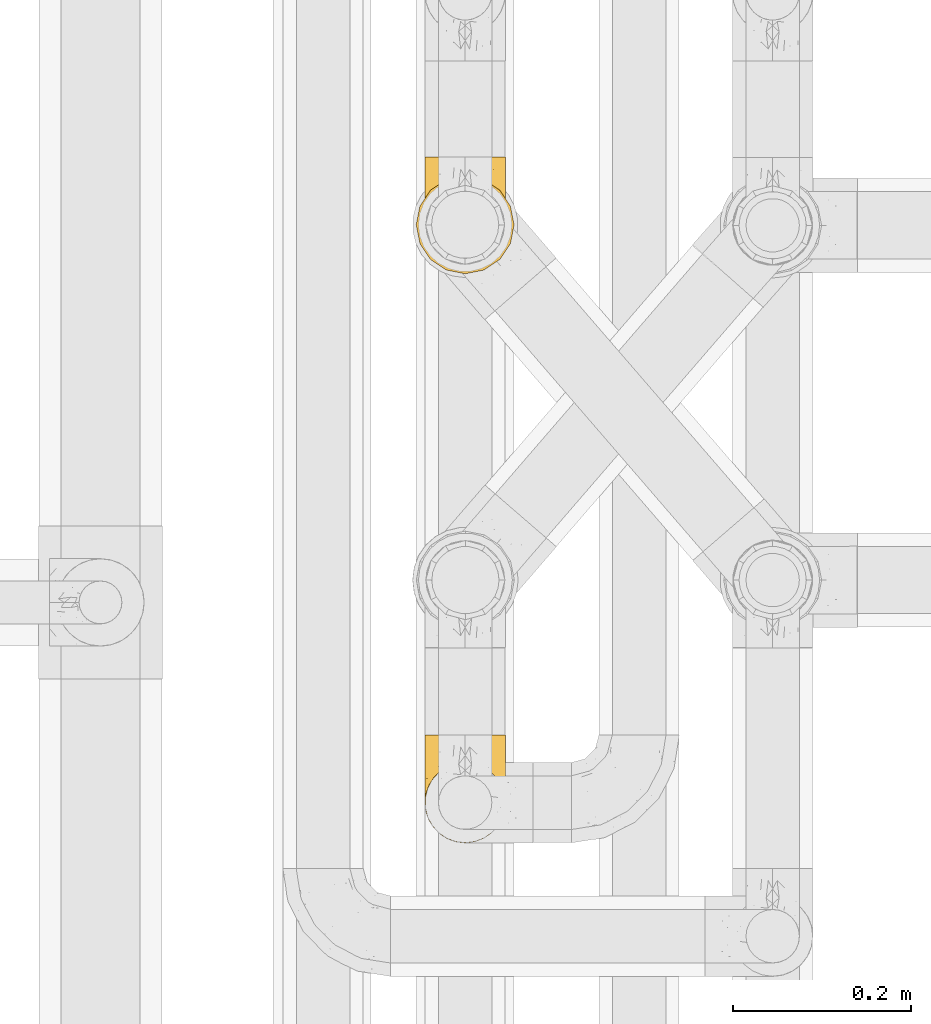
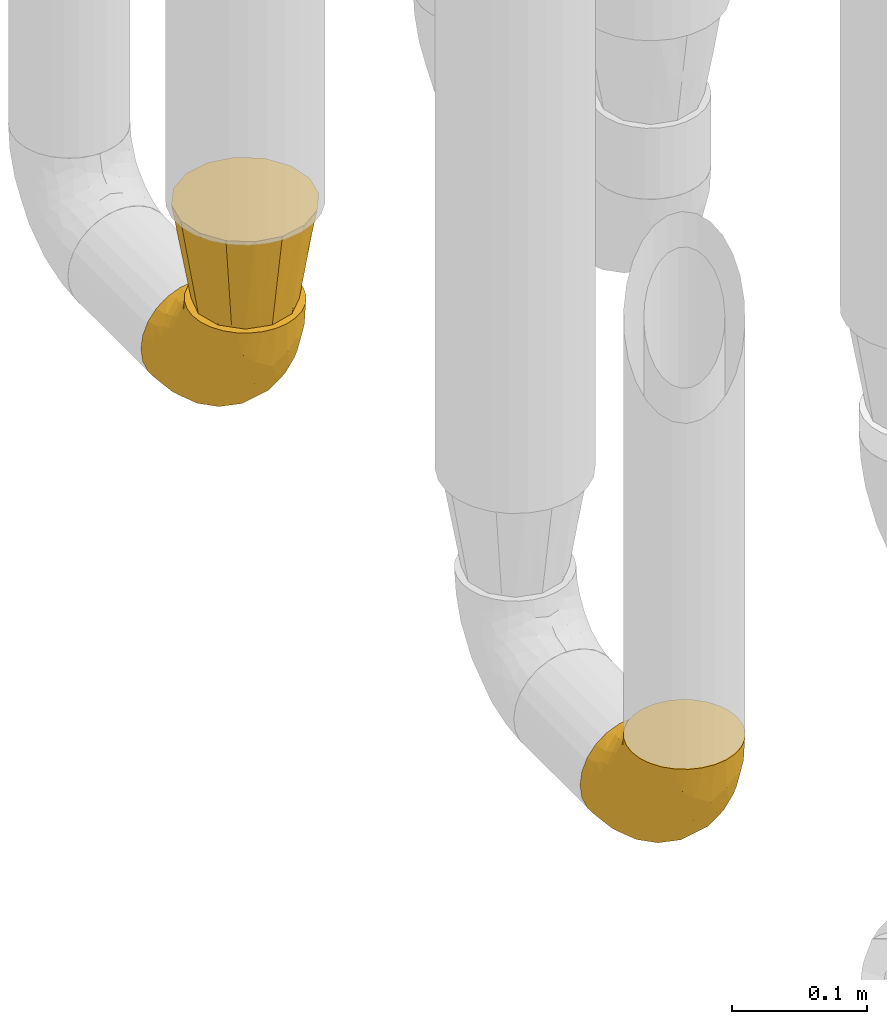
# One storey, part 227 of 827: 3 coverings.
"""IFC2X3 building model written with IfcOpenShell, lengths in millimetres."""

from ifc_helpers import new_model, entity, si_unit, converted_unit, derived_unit, direction, frame, origin, place, context, subcontext, project, spatial, faceted_brep, element, save


model = new_model("IFC2X3")

# Units and contexts
model_context = context("Model", 3, precision=0.01, world=origin(), true_north=direction((6.12303176911189e-17, 1.0)))
body_context = subcontext(model_context, "Body", "Model", "MODEL_VIEW")
ifc_project = project(units=[si_unit("LENGTHUNIT", "METRE", prefix="MILLI"), si_unit("AREAUNIT", "SQUARE_METRE"), si_unit("VOLUMEUNIT", "CUBIC_METRE"), converted_unit("PLANEANGLEUNIT", "DEGREE", entity("IfcRatioMeasure", 0.0174532925199433), si_unit("PLANEANGLEUNIT", "RADIAN"), dimensions=[0, 0, 0, 0, 0, 0, 0]), si_unit("MASSUNIT", "GRAM", prefix="KILO"), derived_unit("MASSDENSITYUNIT", [(si_unit("MASSUNIT", "GRAM", prefix="KILO"), 1), (si_unit("LENGTHUNIT", "METRE"), -3)]), derived_unit("MOMENTOFINERTIAUNIT", [(si_unit("LENGTHUNIT", "METRE"), 4)]), si_unit("TIMEUNIT", "SECOND"), si_unit("FREQUENCYUNIT", "HERTZ"), si_unit("THERMODYNAMICTEMPERATUREUNIT", "DEGREE_CELSIUS"), derived_unit("THERMALTRANSMITTANCEUNIT", [(si_unit("MASSUNIT", "GRAM", prefix="KILO"), 1), (si_unit("THERMODYNAMICTEMPERATUREUNIT", "KELVIN"), -1), (si_unit("TIMEUNIT", "SECOND"), -3)]), derived_unit("VOLUMETRICFLOWRATEUNIT", [(si_unit("LENGTHUNIT", "METRE"), 3), (si_unit("TIMEUNIT", "SECOND"), -1)]), derived_unit("MASSFLOWRATEUNIT", [(si_unit("MASSUNIT", "GRAM", prefix="KILO"), 1), (si_unit("TIMEUNIT", "SECOND"), -1)]), derived_unit("ROTATIONALFREQUENCYUNIT", [(si_unit("TIMEUNIT", "SECOND"), -1)]), si_unit("ELECTRICCURRENTUNIT", "AMPERE"), si_unit("ELECTRICVOLTAGEUNIT", "VOLT"), si_unit("POWERUNIT", "WATT"), si_unit("FORCEUNIT", "NEWTON", prefix="KILO"), si_unit("ILLUMINANCEUNIT", "LUX"), si_unit("LUMINOUSFLUXUNIT", "LUMEN"), si_unit("LUMINOUSINTENSITYUNIT", "CANDELA"), derived_unit("USERDEFINED", [(si_unit("MASSUNIT", "GRAM", prefix="KILO"), -1), (si_unit("LENGTHUNIT", "METRE"), -2), (si_unit("TIMEUNIT", "SECOND"), 3), (si_unit("LUMINOUSFLUXUNIT", "LUMEN"), 1)]), derived_unit("LINEARVELOCITYUNIT", [(si_unit("LENGTHUNIT", "METRE"), 1), (si_unit("TIMEUNIT", "SECOND"), -1)]), si_unit("PRESSUREUNIT", "PASCAL"), derived_unit("USERDEFINED", [(si_unit("LENGTHUNIT", "METRE"), -2), (si_unit("MASSUNIT", "GRAM", prefix="KILO"), 1), (si_unit("TIMEUNIT", "SECOND"), -2)]), derived_unit("LINEARFORCEUNIT", [(si_unit("MASSUNIT", "GRAM", prefix="KILO"), 1), (si_unit("LENGTHUNIT", "METRE"), 1), (si_unit("TIMEUNIT", "SECOND"), -2), (si_unit("LENGTHUNIT", "METRE"), -1)]), derived_unit("PLANARFORCEUNIT", [(si_unit("MASSUNIT", "GRAM", prefix="KILO"), 1), (si_unit("LENGTHUNIT", "METRE"), 1), (si_unit("TIMEUNIT", "SECOND"), -2), (si_unit("LENGTHUNIT", "METRE"), -2)])], contexts=[model_context])

# Site, building, storey
site_placement = place(None, origin())
site = spatial("IfcSite", under=ifc_project, at=site_placement, CompositionType="ELEMENT")
building_placement = place(site_placement, origin())
building = spatial("IfcBuilding", under=site, at=building_placement, CompositionType="ELEMENT")
storey_placement = place(building_placement, frame((0.0, 0.0, 28200.0)))
storey = spatial("IfcBuildingStorey", under=building, at=storey_placement, Name="08", CompositionType="ELEMENT", Elevation=28200.0)

# Coverings
covering_1_placement = place(storey_placement, frame((36582.9, 12933.46, 353.25)))
element("IfcCovering", 1, at=covering_1_placement, inside=storey, Name=":ADSK_", ObjectType=":ADSK_", PredefinedType="INSULATION", context=body_context, shape_type="Brep", body=[
    faceted_brep([(2.73, 36.69, 122.75), (6.07, 27.15, 122.75), (11.45, 18.59, 122.75), (18.6, 11.44, 122.75), (27.16, 6.06, 122.75), (36.7, 2.73, 122.75), (46.75, 1.6, 122.75), (56.8, 2.73, 122.75), (66.34, 6.07, 122.75), (74.9, 11.45, 122.75), (82.05, 18.6, 122.75), (87.43, 27.16, 122.75), (90.76, 36.7, 122.75), (91.9, 46.75, 122.75), (90.76, 56.8, 122.75), (87.42, 66.34, 122.75), (82.04, 74.9, 122.75), (74.89, 82.05, 122.75), (66.33, 87.43, 122.75), (56.79, 90.76, 122.75), (46.75, 91.9, 122.75), (36.69, 90.76, 122.75), (27.15, 87.42, 122.75), (18.59, 82.04, 122.75), (11.44, 74.89, 122.75), (6.06, 66.33, 122.75), (2.73, 56.79, 122.75), (1.6, 46.75, 122.75), (58.43, 122.75, 90.36), (69.32, 122.75, 85.85), (78.67, 122.75, 78.67), (85.85, 122.75, 69.32), (90.36, 122.75, 58.43), (91.9, 122.75, 46.75), (90.36, 122.75, 35.06), (85.85, 122.75, 24.17), (78.67, 122.75, 14.82), (69.32, 122.75, 7.64), (58.43, 122.75, 3.13), (46.75, 122.75, 1.6), (35.06, 122.75, 3.13), (24.17, 122.75, 7.64), (14.82, 122.75, 14.82), (7.64, 122.75, 24.17), (3.13, 122.75, 35.06), (1.6, 122.75, 46.75), (3.13, 122.75, 58.43), (7.64, 122.75, 69.32), (14.82, 122.75, 78.67), (24.17, 122.75, 85.85), (35.06, 122.75, 90.36), (46.75, 122.75, 91.9), (46.75, 24.73, 51.54), (38.29, 29.08, 47.17), (46.75, 38.13, 38.13), (46.75, 85.31, 7.52), (38.96, 93.59, 5.85), (46.75, 100.54, 5.11), (33.86, 63.54, 19.2), (31.42, 38.98, 38.98), (21.63, 50.71, 35.02), (30.84, 93.33, 8.21), (22.16, 75.2, 19.28), (20.56, 100.46, 12.19), (2.29, 41.6, 101.39), (7.18, 80.86, 34.43), (12.6, 94.87, 20.95), (14.0, 67.96, 30.74), (2.81, 52.16, 72.93), (6.65, 52.1, 56.64), (6.11, 36.74, 80.81), (16.62, 17.11, 93.43), (9.76, 23.24, 100.76), (12.46, 29.18, 74.27), (1.6, 52.53, 93.66), (1.6, 60.77, 81.33), (1.6, 69.01, 69.01), (2.46, 100.68, 40.87), (5.91, 103.79, 29.38), (36.97, 16.37, 67.05), (46.75, 7.52, 85.31), (33.09, 7.31, 93.68), (1.6, 93.66, 52.53), (1.6, 102.83, 50.71), (1.6, 112.01, 48.88), (25.62, 18.17, 72.77), (3.14, 71.97, 51.21), (23.92, 9.83, 101.18), (46.75, 5.11, 100.54), (13.58, 45.97, 48.74), (1.6, 48.88, 112.01), (1.6, 50.71, 102.83), (18.5, 22.83, 73.88), (46.75, 51.54, 24.73), (1.6, 81.33, 60.77), (4.96, 31.74, 103.08), (20.84, 32.48, 54.8), (46.75, 68.42, 16.13), (30.52, 25.33, 55.92), (46.75, 16.13, 68.42), (27.29, 92.29, 104.98), (36.89, 94.12, 108.58), (33.6, 100.97, 98.21), (2.54, 95.91, 61.56), (3.27, 107.9, 60.69), (16.85, 87.24, 100.0), (21.91, 95.46, 95.88), (13.5, 90.41, 90.81), (3.96, 74.17, 84.88), (3.52, 83.77, 73.29), (12.17, 76.72, 113.4), (18.93, 84.44, 109.8), (9.34, 76.42, 102.13), (3.12, 90.07, 67.29), (5.67, 99.69, 70.34), (2.51, 61.74, 95.15), (2.53, 58.16, 105.49), (8.35, 112.6, 71.5), (35.39, 110.45, 92.87), (46.75, 107.32, 96.03), (15.1, 108.48, 81.34), (5.27, 66.63, 107.44), (27.43, 115.23, 88.36), (24.89, 105.79, 90.43), (29.71, 89.6, 114.37), (5.07, 69.39, 98.41), (2.88, 66.99, 88.73), (9.69, 102.31, 76.89), (15.51, 99.54, 86.08), (2.27, 55.27, 112.64), (10.03, 82.03, 94.21), (46.75, 94.71, 112.22), (46.75, 96.03, 107.32), (8.83, 94.11, 79.95), (7.16, 84.21, 84.51), (46.75, 101.67, 101.67), (46.75, 112.22, 94.71), (78.39, 108.48, 81.34), (83.8, 102.31, 76.89), (77.97, 99.54, 86.08), (84.66, 94.11, 79.96), (58.1, 110.46, 92.87), (81.31, 76.74, 113.41), (91.9, 50.71, 102.83), (90.96, 58.17, 105.5), (91.22, 55.27, 112.64), (56.59, 94.12, 108.58), (66.18, 92.3, 104.98), (59.87, 100.98, 98.2), (88.42, 69.41, 98.4), (84.13, 76.44, 102.13), (88.22, 66.65, 107.44), (66.06, 115.24, 88.36), (91.9, 102.83, 50.71), (91.9, 112.01, 48.88), (83.44, 82.05, 94.22), (76.62, 87.25, 100.01), (85.14, 112.6, 71.5), (90.22, 107.9, 60.69), (91.9, 93.66, 52.53), (71.55, 95.48, 95.89), (63.77, 89.6, 114.37), (91.9, 60.77, 81.33), (91.9, 69.01, 69.01), (89.53, 74.17, 84.88), (91.9, 48.88, 112.01), (74.55, 84.45, 109.8), (90.95, 95.91, 61.56), (90.37, 90.07, 67.29), (91.9, 81.33, 60.77), (90.98, 61.75, 95.14), (89.97, 83.77, 73.29), (86.32, 84.21, 84.53), (91.9, 52.53, 93.66), (79.97, 90.42, 90.82), (90.61, 67.0, 88.73), (87.82, 99.69, 70.34), (68.6, 105.8, 90.43), (80.89, 94.87, 20.95), (86.31, 80.86, 34.43), (79.49, 67.95, 30.74), (71.33, 75.17, 19.29), (71.88, 50.65, 35.07), (90.35, 71.97, 51.21), (86.85, 52.08, 56.67), (72.67, 32.46, 54.85), (62.08, 38.98, 38.98), (87.58, 103.79, 29.38), (91.03, 100.68, 40.87), (59.62, 63.54, 19.2), (62.65, 93.32, 8.21), (54.53, 93.59, 5.85), (72.93, 100.44, 12.19), (90.68, 52.17, 72.93), (87.39, 36.75, 80.83), (91.2, 41.61, 101.39), (60.41, 7.31, 93.69), (76.88, 17.12, 93.43), (56.53, 16.37, 67.04), (83.74, 23.26, 100.76), (67.88, 18.17, 72.78), (62.99, 25.33, 55.93), (69.58, 9.84, 101.18), (81.04, 29.19, 74.27), (75.0, 22.84, 73.89), (88.53, 31.75, 103.09), (79.93, 45.96, 48.78), (55.21, 29.07, 47.19)], [[[0, 1, 2, 3, 4, 5, 6, 7, 8, 9, 10, 11, 12, 13, 14, 15, 16, 17, 18, 19, 20, 21, 22, 23, 24, 25, 26, 27]], [[28, 29, 30, 31, 32, 33, 34, 35, 36, 37, 38, 39, 40, 41, 42, 43, 44, 45, 46, 47, 48, 49, 50, 51]], [[52, 53, 54]], [[55, 56, 57]], [[58, 59, 60]], [[61, 62, 63]], [[27, 64, 0]], [[65, 66, 67]], [[41, 40, 61]], [[68, 69, 70]], [[66, 43, 42]], [[63, 42, 41]], [[71, 72, 73]], [[72, 2, 1]], [[68, 74, 75, 76]], [[45, 44, 77]], [[43, 78, 44]], [[79, 80, 81]], [[77, 82, 83, 84, 45]], [[79, 81, 85]], [[71, 2, 72]], [[65, 86, 77]], [[4, 81, 5]], [[66, 65, 78]], [[4, 3, 87]], [[81, 88, 5]], [[63, 66, 42]], [[68, 70, 64]], [[67, 60, 89]], [[71, 3, 2]], [[64, 27, 90, 91, 74]], [[92, 71, 73]], [[40, 57, 56]], [[59, 93, 54]], [[86, 76, 94, 82]], [[1, 0, 95]], [[58, 62, 61]], [[60, 96, 89]], [[85, 81, 87]], [[56, 97, 58]], [[65, 67, 69]], [[87, 81, 4]], [[67, 89, 69]], [[61, 63, 41]], [[95, 72, 1]], [[73, 72, 70]], [[69, 73, 70]], [[73, 89, 96]], [[3, 71, 87]], [[85, 87, 71]], [[58, 61, 56]], [[59, 58, 93]], [[76, 86, 68]], [[69, 89, 73]], [[68, 86, 69]], [[65, 69, 86]], [[68, 64, 74]], [[95, 64, 70]], [[98, 79, 85]], [[79, 52, 99, 80]], [[66, 62, 67]], [[62, 58, 60]], [[62, 60, 67]], [[59, 98, 96]], [[59, 96, 60]], [[96, 85, 92]], [[88, 81, 80]], [[88, 6, 5]], [[66, 63, 62]], [[64, 95, 0]], [[72, 95, 70]], [[77, 44, 78]], [[86, 82, 77]], [[40, 39, 57]], [[96, 98, 85]], [[40, 56, 61]], [[66, 78, 43]], [[77, 78, 65]], [[79, 98, 53]], [[96, 92, 73]], [[85, 71, 92]], [[97, 56, 55]], [[97, 93, 58]], [[53, 98, 59]], [[54, 53, 59]], [[79, 53, 52]], [[100, 101, 102]], [[46, 45, 84, 83]], [[103, 104, 82]], [[82, 104, 83]], [[105, 106, 107]], [[108, 109, 76]], [[110, 111, 112]], [[103, 113, 114]], [[115, 74, 116]], [[48, 47, 117]], [[118, 102, 119]], [[49, 48, 120]], [[74, 91, 116]], [[116, 121, 115]], [[49, 122, 50]], [[123, 106, 102]], [[124, 111, 22]], [[125, 126, 115]], [[23, 22, 111]], [[24, 110, 121]], [[120, 127, 128]], [[90, 26, 129]], [[27, 26, 90]], [[121, 125, 115]], [[24, 121, 25]], [[130, 105, 107]], [[129, 25, 116]], [[21, 20, 131]], [[120, 123, 122]], [[112, 105, 130]], [[50, 118, 51]], [[21, 124, 22]], [[101, 131, 132]], [[117, 120, 48]], [[24, 23, 110]], [[127, 114, 133]], [[75, 108, 76]], [[107, 134, 130]], [[133, 114, 113]], [[129, 116, 91]], [[25, 121, 116]], [[121, 112, 125]], [[75, 74, 115]], [[101, 135, 102]], [[131, 101, 21]], [[101, 100, 124]], [[128, 127, 133]], [[119, 136, 51, 118]], [[104, 47, 46]], [[83, 104, 46]], [[117, 104, 114]], [[101, 124, 21]], [[111, 124, 100]], [[102, 118, 123]], [[133, 134, 107]], [[111, 110, 23]], [[114, 104, 103]], [[94, 76, 109]], [[121, 110, 112]], [[122, 118, 50]], [[134, 109, 108]], [[133, 107, 128]], [[112, 108, 125]], [[126, 125, 108]], [[108, 75, 126]], [[75, 115, 126]], [[109, 134, 133]], [[130, 108, 112]], [[108, 130, 134]], [[105, 112, 111]], [[111, 100, 105]], [[106, 105, 100]], [[102, 106, 100]], [[128, 106, 123]], [[90, 129, 91]], [[25, 129, 26]], [[104, 117, 47]], [[117, 114, 127]], [[82, 94, 103]], [[113, 94, 109]], [[94, 113, 103]], [[133, 113, 109]], [[106, 128, 107]], [[123, 120, 128]], [[120, 122, 49]], [[118, 122, 123]], [[135, 101, 132]], [[135, 119, 102]], [[117, 127, 120]], [[30, 29, 137]], [[138, 139, 140]], [[51, 136, 119, 141]], [[142, 17, 16]], [[143, 144, 145]], [[146, 147, 148]], [[149, 150, 151]], [[152, 29, 28]], [[33, 32, 153, 154]], [[150, 155, 156]], [[157, 31, 30]], [[153, 158, 159]], [[29, 152, 137]], [[148, 141, 119]], [[156, 160, 147]], [[148, 135, 146]], [[137, 138, 157]], [[19, 161, 146]], [[162, 163, 164]], [[14, 13, 165]], [[153, 32, 158]], [[147, 161, 166]], [[18, 17, 166]], [[167, 168, 169]], [[166, 150, 156]], [[151, 150, 142]], [[151, 170, 149]], [[151, 16, 15]], [[171, 140, 172]], [[165, 143, 145]], [[173, 170, 144]], [[142, 166, 17]], [[19, 131, 20]], [[144, 170, 151]], [[18, 161, 19]], [[173, 144, 143]], [[140, 139, 174]], [[171, 164, 163]], [[164, 172, 155]], [[151, 15, 144]], [[145, 15, 14]], [[173, 162, 170]], [[149, 175, 164]], [[19, 146, 131]], [[132, 131, 146]], [[160, 148, 147]], [[159, 158, 167]], [[135, 132, 146]], [[158, 32, 31]], [[157, 158, 31]], [[167, 158, 176]], [[166, 161, 18]], [[146, 161, 147]], [[148, 177, 141]], [[171, 168, 140]], [[171, 163, 169]], [[151, 142, 16]], [[166, 142, 150]], [[152, 141, 177]], [[51, 141, 28]], [[138, 140, 176]], [[172, 140, 174]], [[175, 149, 170]], [[164, 150, 149]], [[170, 162, 175]], [[162, 164, 175]], [[155, 172, 174]], [[171, 172, 164]], [[155, 174, 156]], [[164, 155, 150]], [[160, 156, 174]], [[147, 166, 156]], [[139, 160, 174]], [[148, 160, 177]], [[15, 145, 144]], [[165, 145, 14]], [[137, 157, 30]], [[158, 157, 176]], [[168, 167, 176]], [[169, 159, 167]], [[140, 168, 176]], [[169, 168, 171]], [[137, 177, 139]], [[160, 139, 177]], [[141, 152, 28]], [[137, 152, 177]], [[148, 119, 135]], [[157, 138, 176]], [[139, 138, 137]], [[178, 179, 180]], [[181, 180, 182]], [[179, 183, 184]], [[185, 186, 182]], [[187, 188, 179]], [[188, 33, 154, 153, 159]], [[181, 189, 190]], [[35, 34, 187]], [[191, 38, 190]], [[192, 178, 181]], [[179, 184, 180]], [[192, 190, 37]], [[37, 190, 38]], [[36, 35, 178]], [[54, 93, 186]], [[35, 187, 178]], [[193, 194, 184]], [[195, 173, 143, 165, 13]], [[195, 193, 173]], [[193, 163, 162, 173]], [[13, 12, 195]], [[8, 7, 196]], [[9, 197, 10]], [[198, 80, 99, 52]], [[196, 7, 88]], [[197, 199, 10]], [[182, 189, 181]], [[200, 198, 201]], [[200, 196, 198]], [[9, 8, 202]], [[194, 199, 203]], [[192, 37, 36]], [[80, 196, 88]], [[183, 159, 169, 163]], [[188, 34, 33]], [[202, 200, 197]], [[185, 203, 204]], [[202, 8, 196]], [[10, 199, 11]], [[12, 11, 205]], [[38, 191, 57]], [[189, 97, 191]], [[203, 199, 197]], [[205, 199, 194]], [[204, 203, 197]], [[184, 203, 206]], [[200, 202, 196]], [[197, 9, 202]], [[207, 54, 186]], [[97, 55, 191]], [[194, 203, 184]], [[183, 163, 193]], [[184, 206, 180]], [[183, 193, 184]], [[205, 195, 12]], [[193, 195, 194]], [[80, 198, 196]], [[207, 186, 201]], [[182, 180, 206]], [[181, 178, 180]], [[185, 182, 206]], [[182, 186, 189]], [[203, 185, 206]], [[185, 200, 201]], [[7, 6, 88]], [[178, 192, 36]], [[190, 192, 181]], [[199, 205, 11]], [[195, 205, 194]], [[159, 183, 188]], [[179, 188, 183]], [[57, 191, 55]], [[57, 39, 38]], [[189, 191, 190]], [[188, 187, 34]], [[178, 187, 179]], [[186, 93, 189]], [[197, 200, 204]], [[185, 204, 200]], [[189, 93, 97]], [[207, 198, 52]], [[185, 201, 186]], [[198, 207, 201]], [[54, 207, 52]]]),
])
covering_2_placement = place(storey_placement, frame((36573.05, 12923.61, 476.0)))
element("IfcCovering", 2, at=covering_2_placement, inside=storey, Name=":ADSK_", ObjectType=":ADSK_", PredefinedType="INSULATION", context=body_context, shape_type="Brep", body=[
    faceted_brep([(77.64, 107.41, 89.0), (67.12, 109.5, 89.0), (56.6, 111.6, 89.0), (46.07, 109.5, 89.0), (35.55, 107.41, 89.0), (26.63, 101.45, 89.0), (17.7, 95.49, 89.0), (11.74, 86.56, 89.0), (5.78, 77.64, 89.0), (3.69, 67.12, 89.0), (1.6, 56.6, 89.0), (3.69, 46.07, 89.0), (5.78, 35.55, 89.0), (11.74, 26.63, 89.0), (17.7, 17.7, 89.0), (26.63, 11.74, 89.0), (35.55, 5.78, 89.0), (46.07, 3.69, 89.0), (56.6, 1.6, 89.0), (67.12, 3.69, 89.0), (77.64, 5.78, 89.0), (86.56, 11.74, 89.0), (95.49, 17.7, 89.0), (101.45, 26.63, 89.0), (107.41, 35.55, 89.0), (109.5, 46.07, 89.0), (111.6, 56.6, 89.0), (109.5, 67.12, 89.0), (107.41, 77.64, 89.0), (101.45, 86.56, 89.0), (95.49, 95.49, 89.0), (86.56, 101.45, 89.0), (91.24, 36.6, 0.0), (83.92, 29.27, 0.0), (76.6, 21.95, 0.0), (66.6, 19.27, 0.0), (56.6, 16.6, 0.0), (46.6, 19.27, 0.0), (36.6, 21.95, 0.0), (29.27, 29.27, 0.0), (21.95, 36.6, 0.0), (19.27, 46.6, 0.0), (16.6, 56.6, 0.0), (19.27, 66.6, 0.0), (21.95, 76.6, 0.0), (29.27, 83.92, 0.0), (36.6, 91.24, 0.0), (46.6, 93.92, 0.0), (56.6, 96.6, 0.0), (66.6, 93.92, 0.0), (76.6, 91.24, 0.0), (83.92, 83.92, 0.0), (91.24, 76.6, 0.0), (93.92, 66.6, 0.0), (96.6, 56.6, 0.0), (93.92, 46.6, 0.0)], [[[0, 1, 2, 3, 4, 5, 6, 7, 8, 9, 10, 11, 12, 13, 14, 15, 16, 17, 18, 19, 20, 21, 22, 23, 24, 25, 26, 27, 28, 29, 30, 31]], [[32, 33, 34, 35, 36, 37, 38, 39, 40, 41, 42, 43, 44, 45, 46, 47, 48, 49, 50, 51, 52, 53, 54, 55]], [[3, 2, 48]], [[44, 7, 45]], [[45, 5, 46]], [[48, 47, 3]], [[6, 45, 7]], [[44, 8, 7]], [[5, 45, 6]], [[42, 9, 43]], [[5, 4, 46]], [[47, 46, 4]], [[9, 42, 10]], [[8, 44, 43]], [[9, 8, 43]], [[47, 4, 3]], [[11, 10, 42]], [[38, 15, 39]], [[39, 13, 40]], [[42, 41, 11]], [[14, 39, 15]], [[38, 16, 15]], [[13, 39, 14]], [[36, 17, 37]], [[13, 12, 40]], [[41, 40, 12]], [[17, 36, 18]], [[16, 38, 37]], [[17, 16, 37]], [[41, 12, 11]], [[19, 18, 36]], [[32, 23, 33]], [[33, 21, 34]], [[36, 35, 19]], [[22, 33, 23]], [[32, 24, 23]], [[21, 33, 22]], [[54, 25, 55]], [[21, 20, 34]], [[35, 34, 20]], [[25, 54, 26]], [[24, 32, 55]], [[25, 24, 55]], [[35, 20, 19]], [[27, 26, 54]], [[50, 31, 51]], [[51, 29, 52]], [[54, 53, 27]], [[30, 51, 31]], [[50, 0, 31]], [[29, 51, 30]], [[48, 1, 49]], [[29, 28, 52]], [[53, 52, 28]], [[1, 48, 2]], [[0, 50, 49]], [[1, 0, 49]], [[53, 28, 27]]]),
])
covering_3_placement = place(storey_placement, frame((36582.9, 12284.43, 353.25)))
element("IfcCovering", 3, at=covering_3_placement, inside=storey, Name=":ADSK_", ObjectType=":ADSK_", PredefinedType="INSULATION", context=body_context, shape_type="Brep", body=[
    faceted_brep([(2.73, 36.69, 122.75), (6.07, 27.15, 122.75), (11.45, 18.59, 122.75), (18.6, 11.44, 122.75), (27.16, 6.06, 122.75), (36.7, 2.73, 122.75), (46.75, 1.6, 122.75), (56.8, 2.73, 122.75), (66.34, 6.07, 122.75), (74.9, 11.45, 122.75), (82.05, 18.6, 122.75), (87.43, 27.16, 122.75), (90.76, 36.7, 122.75), (91.9, 46.75, 122.75), (90.76, 56.8, 122.75), (87.42, 66.34, 122.75), (82.04, 74.9, 122.75), (74.89, 82.05, 122.75), (66.33, 87.43, 122.75), (56.79, 90.76, 122.75), (46.75, 91.9, 122.75), (36.69, 90.76, 122.75), (27.15, 87.42, 122.75), (18.59, 82.04, 122.75), (11.44, 74.89, 122.75), (6.06, 66.33, 122.75), (2.73, 56.79, 122.75), (1.6, 46.75, 122.75), (58.43, 122.75, 90.36), (69.32, 122.75, 85.85), (78.67, 122.75, 78.67), (85.85, 122.75, 69.32), (90.36, 122.75, 58.43), (91.9, 122.75, 46.75), (90.36, 122.75, 35.06), (85.85, 122.75, 24.17), (78.67, 122.75, 14.82), (69.32, 122.75, 7.64), (58.43, 122.75, 3.13), (46.75, 122.75, 1.6), (35.06, 122.75, 3.13), (24.17, 122.75, 7.64), (14.82, 122.75, 14.82), (7.64, 122.75, 24.17), (3.13, 122.75, 35.06), (1.6, 122.75, 46.75), (3.13, 122.75, 58.43), (7.64, 122.75, 69.32), (14.82, 122.75, 78.67), (24.17, 122.75, 85.85), (35.06, 122.75, 90.36), (46.75, 122.75, 91.9), (46.75, 24.73, 51.54), (38.29, 29.08, 47.17), (46.75, 38.13, 38.13), (46.75, 85.31, 7.52), (38.96, 93.59, 5.85), (46.75, 100.54, 5.11), (33.86, 63.54, 19.2), (31.42, 38.98, 38.98), (21.63, 50.71, 35.02), (30.84, 93.33, 8.21), (22.16, 75.2, 19.28), (20.56, 100.46, 12.19), (2.29, 41.6, 101.39), (7.18, 80.86, 34.43), (12.6, 94.87, 20.95), (14.0, 67.96, 30.74), (2.81, 52.16, 72.93), (6.65, 52.1, 56.64), (6.11, 36.74, 80.81), (16.62, 17.11, 93.43), (9.76, 23.24, 100.76), (12.46, 29.18, 74.27), (1.6, 52.53, 93.66), (1.6, 60.77, 81.33), (1.6, 69.01, 69.01), (2.46, 100.68, 40.87), (5.91, 103.79, 29.38), (36.97, 16.37, 67.05), (46.75, 7.52, 85.31), (33.09, 7.31, 93.68), (1.6, 93.66, 52.53), (1.6, 102.83, 50.71), (1.6, 112.01, 48.88), (25.62, 18.17, 72.77), (3.14, 71.97, 51.21), (23.92, 9.83, 101.18), (46.75, 5.11, 100.54), (13.58, 45.97, 48.74), (1.6, 48.88, 112.01), (1.6, 50.71, 102.83), (18.5, 22.83, 73.88), (46.75, 51.54, 24.73), (1.6, 81.33, 60.77), (4.96, 31.74, 103.08), (20.84, 32.48, 54.8), (46.75, 68.42, 16.13), (30.52, 25.33, 55.92), (46.75, 16.13, 68.42), (27.29, 92.29, 104.98), (36.89, 94.12, 108.58), (33.6, 100.97, 98.21), (2.54, 95.91, 61.56), (3.27, 107.9, 60.69), (16.85, 87.24, 100.0), (21.91, 95.46, 95.88), (13.5, 90.41, 90.81), (3.96, 74.17, 84.88), (3.52, 83.77, 73.29), (12.17, 76.72, 113.4), (18.93, 84.44, 109.8), (9.34, 76.42, 102.13), (3.12, 90.07, 67.29), (5.67, 99.69, 70.34), (2.51, 61.74, 95.15), (2.53, 58.16, 105.49), (8.35, 112.6, 71.5), (35.39, 110.45, 92.87), (46.75, 107.32, 96.03), (15.1, 108.48, 81.34), (5.27, 66.63, 107.44), (27.43, 115.23, 88.36), (24.89, 105.79, 90.43), (29.71, 89.6, 114.37), (5.07, 69.39, 98.41), (2.88, 66.99, 88.73), (9.69, 102.31, 76.89), (15.51, 99.54, 86.08), (2.27, 55.27, 112.64), (10.03, 82.03, 94.21), (46.75, 94.71, 112.22), (46.75, 96.03, 107.32), (8.83, 94.11, 79.95), (7.16, 84.21, 84.51), (46.75, 101.67, 101.67), (46.75, 112.22, 94.71), (78.39, 108.48, 81.34), (83.8, 102.31, 76.89), (77.97, 99.54, 86.08), (84.66, 94.11, 79.96), (58.1, 110.46, 92.87), (81.31, 76.74, 113.41), (91.9, 50.71, 102.83), (90.96, 58.17, 105.5), (91.22, 55.27, 112.64), (56.59, 94.12, 108.58), (66.18, 92.3, 104.98), (59.87, 100.98, 98.2), (88.42, 69.41, 98.4), (84.13, 76.44, 102.13), (88.22, 66.65, 107.44), (66.06, 115.24, 88.36), (91.9, 102.83, 50.71), (91.9, 112.01, 48.88), (83.44, 82.05, 94.22), (76.62, 87.25, 100.01), (85.14, 112.6, 71.5), (90.22, 107.9, 60.69), (91.9, 93.66, 52.53), (71.55, 95.48, 95.89), (63.77, 89.6, 114.37), (91.9, 60.77, 81.33), (91.9, 69.01, 69.01), (89.53, 74.17, 84.88), (91.9, 48.88, 112.01), (74.55, 84.45, 109.8), (90.95, 95.91, 61.56), (90.37, 90.07, 67.29), (91.9, 81.33, 60.77), (90.98, 61.75, 95.14), (89.97, 83.77, 73.29), (86.32, 84.21, 84.53), (91.9, 52.53, 93.66), (79.97, 90.42, 90.82), (90.61, 67.0, 88.73), (87.82, 99.69, 70.34), (68.6, 105.8, 90.43), (80.89, 94.87, 20.95), (86.31, 80.86, 34.43), (79.49, 67.95, 30.74), (71.33, 75.17, 19.29), (71.88, 50.65, 35.07), (90.35, 71.97, 51.21), (86.85, 52.08, 56.67), (72.67, 32.46, 54.85), (62.08, 38.98, 38.98), (87.58, 103.79, 29.38), (91.03, 100.68, 40.87), (59.62, 63.54, 19.2), (62.65, 93.32, 8.21), (54.53, 93.59, 5.85), (72.93, 100.44, 12.19), (90.68, 52.17, 72.93), (87.39, 36.75, 80.83), (91.2, 41.61, 101.39), (60.41, 7.31, 93.69), (76.88, 17.12, 93.43), (56.53, 16.37, 67.04), (83.74, 23.26, 100.76), (67.88, 18.17, 72.78), (62.99, 25.33, 55.93), (69.58, 9.84, 101.18), (81.04, 29.19, 74.27), (75.0, 22.84, 73.89), (88.53, 31.75, 103.09), (79.93, 45.96, 48.78), (55.21, 29.07, 47.19)], [[[0, 1, 2, 3, 4, 5, 6, 7, 8, 9, 10, 11, 12, 13, 14, 15, 16, 17, 18, 19, 20, 21, 22, 23, 24, 25, 26, 27]], [[28, 29, 30, 31, 32, 33, 34, 35, 36, 37, 38, 39, 40, 41, 42, 43, 44, 45, 46, 47, 48, 49, 50, 51]], [[52, 53, 54]], [[55, 56, 57]], [[58, 59, 60]], [[61, 62, 63]], [[27, 64, 0]], [[65, 66, 67]], [[41, 40, 61]], [[68, 69, 70]], [[66, 43, 42]], [[63, 42, 41]], [[71, 72, 73]], [[72, 2, 1]], [[68, 74, 75, 76]], [[45, 44, 77]], [[43, 78, 44]], [[79, 80, 81]], [[77, 82, 83, 84, 45]], [[79, 81, 85]], [[71, 2, 72]], [[65, 86, 77]], [[4, 81, 5]], [[66, 65, 78]], [[4, 3, 87]], [[81, 88, 5]], [[63, 66, 42]], [[68, 70, 64]], [[67, 60, 89]], [[71, 3, 2]], [[64, 27, 90, 91, 74]], [[92, 71, 73]], [[40, 57, 56]], [[59, 93, 54]], [[86, 76, 94, 82]], [[1, 0, 95]], [[58, 62, 61]], [[60, 96, 89]], [[85, 81, 87]], [[56, 97, 58]], [[65, 67, 69]], [[87, 81, 4]], [[67, 89, 69]], [[61, 63, 41]], [[95, 72, 1]], [[73, 72, 70]], [[69, 73, 70]], [[73, 89, 96]], [[3, 71, 87]], [[85, 87, 71]], [[58, 61, 56]], [[59, 58, 93]], [[76, 86, 68]], [[69, 89, 73]], [[68, 86, 69]], [[65, 69, 86]], [[68, 64, 74]], [[95, 64, 70]], [[98, 79, 85]], [[79, 52, 99, 80]], [[66, 62, 67]], [[62, 58, 60]], [[62, 60, 67]], [[59, 98, 96]], [[59, 96, 60]], [[96, 85, 92]], [[88, 81, 80]], [[88, 6, 5]], [[66, 63, 62]], [[64, 95, 0]], [[72, 95, 70]], [[77, 44, 78]], [[86, 82, 77]], [[40, 39, 57]], [[96, 98, 85]], [[40, 56, 61]], [[66, 78, 43]], [[77, 78, 65]], [[79, 98, 53]], [[96, 92, 73]], [[85, 71, 92]], [[97, 56, 55]], [[97, 93, 58]], [[53, 98, 59]], [[54, 53, 59]], [[79, 53, 52]], [[100, 101, 102]], [[46, 45, 84, 83]], [[103, 104, 82]], [[82, 104, 83]], [[105, 106, 107]], [[108, 109, 76]], [[110, 111, 112]], [[103, 113, 114]], [[115, 74, 116]], [[48, 47, 117]], [[118, 102, 119]], [[49, 48, 120]], [[74, 91, 116]], [[116, 121, 115]], [[49, 122, 50]], [[123, 106, 102]], [[124, 111, 22]], [[125, 126, 115]], [[23, 22, 111]], [[24, 110, 121]], [[120, 127, 128]], [[90, 26, 129]], [[27, 26, 90]], [[121, 125, 115]], [[24, 121, 25]], [[130, 105, 107]], [[129, 25, 116]], [[21, 20, 131]], [[120, 123, 122]], [[112, 105, 130]], [[50, 118, 51]], [[21, 124, 22]], [[101, 131, 132]], [[117, 120, 48]], [[24, 23, 110]], [[127, 114, 133]], [[75, 108, 76]], [[107, 134, 130]], [[133, 114, 113]], [[129, 116, 91]], [[25, 121, 116]], [[121, 112, 125]], [[75, 74, 115]], [[101, 135, 102]], [[131, 101, 21]], [[101, 100, 124]], [[128, 127, 133]], [[119, 136, 51, 118]], [[104, 47, 46]], [[83, 104, 46]], [[117, 104, 114]], [[101, 124, 21]], [[111, 124, 100]], [[102, 118, 123]], [[133, 134, 107]], [[111, 110, 23]], [[114, 104, 103]], [[94, 76, 109]], [[121, 110, 112]], [[122, 118, 50]], [[134, 109, 108]], [[133, 107, 128]], [[112, 108, 125]], [[126, 125, 108]], [[108, 75, 126]], [[75, 115, 126]], [[109, 134, 133]], [[130, 108, 112]], [[108, 130, 134]], [[105, 112, 111]], [[111, 100, 105]], [[106, 105, 100]], [[102, 106, 100]], [[128, 106, 123]], [[90, 129, 91]], [[25, 129, 26]], [[104, 117, 47]], [[117, 114, 127]], [[82, 94, 103]], [[113, 94, 109]], [[94, 113, 103]], [[133, 113, 109]], [[106, 128, 107]], [[123, 120, 128]], [[120, 122, 49]], [[118, 122, 123]], [[135, 101, 132]], [[135, 119, 102]], [[117, 127, 120]], [[30, 29, 137]], [[138, 139, 140]], [[51, 136, 119, 141]], [[142, 17, 16]], [[143, 144, 145]], [[146, 147, 148]], [[149, 150, 151]], [[152, 29, 28]], [[33, 32, 153, 154]], [[150, 155, 156]], [[157, 31, 30]], [[153, 158, 159]], [[29, 152, 137]], [[148, 141, 119]], [[156, 160, 147]], [[148, 135, 146]], [[137, 138, 157]], [[19, 161, 146]], [[162, 163, 164]], [[14, 13, 165]], [[153, 32, 158]], [[147, 161, 166]], [[18, 17, 166]], [[167, 168, 169]], [[166, 150, 156]], [[151, 150, 142]], [[151, 170, 149]], [[151, 16, 15]], [[171, 140, 172]], [[165, 143, 145]], [[173, 170, 144]], [[142, 166, 17]], [[19, 131, 20]], [[144, 170, 151]], [[18, 161, 19]], [[173, 144, 143]], [[140, 139, 174]], [[171, 164, 163]], [[164, 172, 155]], [[151, 15, 144]], [[145, 15, 14]], [[173, 162, 170]], [[149, 175, 164]], [[19, 146, 131]], [[132, 131, 146]], [[160, 148, 147]], [[159, 158, 167]], [[135, 132, 146]], [[158, 32, 31]], [[157, 158, 31]], [[167, 158, 176]], [[166, 161, 18]], [[146, 161, 147]], [[148, 177, 141]], [[171, 168, 140]], [[171, 163, 169]], [[151, 142, 16]], [[166, 142, 150]], [[152, 141, 177]], [[51, 141, 28]], [[138, 140, 176]], [[172, 140, 174]], [[175, 149, 170]], [[164, 150, 149]], [[170, 162, 175]], [[162, 164, 175]], [[155, 172, 174]], [[171, 172, 164]], [[155, 174, 156]], [[164, 155, 150]], [[160, 156, 174]], [[147, 166, 156]], [[139, 160, 174]], [[148, 160, 177]], [[15, 145, 144]], [[165, 145, 14]], [[137, 157, 30]], [[158, 157, 176]], [[168, 167, 176]], [[169, 159, 167]], [[140, 168, 176]], [[169, 168, 171]], [[137, 177, 139]], [[160, 139, 177]], [[141, 152, 28]], [[137, 152, 177]], [[148, 119, 135]], [[157, 138, 176]], [[139, 138, 137]], [[178, 179, 180]], [[181, 180, 182]], [[179, 183, 184]], [[185, 186, 182]], [[187, 188, 179]], [[188, 33, 154, 153, 159]], [[181, 189, 190]], [[35, 34, 187]], [[191, 38, 190]], [[192, 178, 181]], [[179, 184, 180]], [[192, 190, 37]], [[37, 190, 38]], [[36, 35, 178]], [[54, 93, 186]], [[35, 187, 178]], [[193, 194, 184]], [[195, 173, 143, 165, 13]], [[195, 193, 173]], [[193, 163, 162, 173]], [[13, 12, 195]], [[8, 7, 196]], [[9, 197, 10]], [[198, 80, 99, 52]], [[196, 7, 88]], [[197, 199, 10]], [[182, 189, 181]], [[200, 198, 201]], [[200, 196, 198]], [[9, 8, 202]], [[194, 199, 203]], [[192, 37, 36]], [[80, 196, 88]], [[183, 159, 169, 163]], [[188, 34, 33]], [[202, 200, 197]], [[185, 203, 204]], [[202, 8, 196]], [[10, 199, 11]], [[12, 11, 205]], [[38, 191, 57]], [[189, 97, 191]], [[203, 199, 197]], [[205, 199, 194]], [[204, 203, 197]], [[184, 203, 206]], [[200, 202, 196]], [[197, 9, 202]], [[207, 54, 186]], [[97, 55, 191]], [[194, 203, 184]], [[183, 163, 193]], [[184, 206, 180]], [[183, 193, 184]], [[205, 195, 12]], [[193, 195, 194]], [[80, 198, 196]], [[207, 186, 201]], [[182, 180, 206]], [[181, 178, 180]], [[185, 182, 206]], [[182, 186, 189]], [[203, 185, 206]], [[185, 200, 201]], [[7, 6, 88]], [[178, 192, 36]], [[190, 192, 181]], [[199, 205, 11]], [[195, 205, 194]], [[159, 183, 188]], [[179, 188, 183]], [[57, 191, 55]], [[57, 39, 38]], [[189, 191, 190]], [[188, 187, 34]], [[178, 187, 179]], [[186, 93, 189]], [[197, 200, 204]], [[185, 204, 200]], [[189, 93, 97]], [[207, 198, 52]], [[185, 201, 186]], [[198, 207, 201]], [[54, 207, 52]]]),
])

save(model, "model.ifc")
